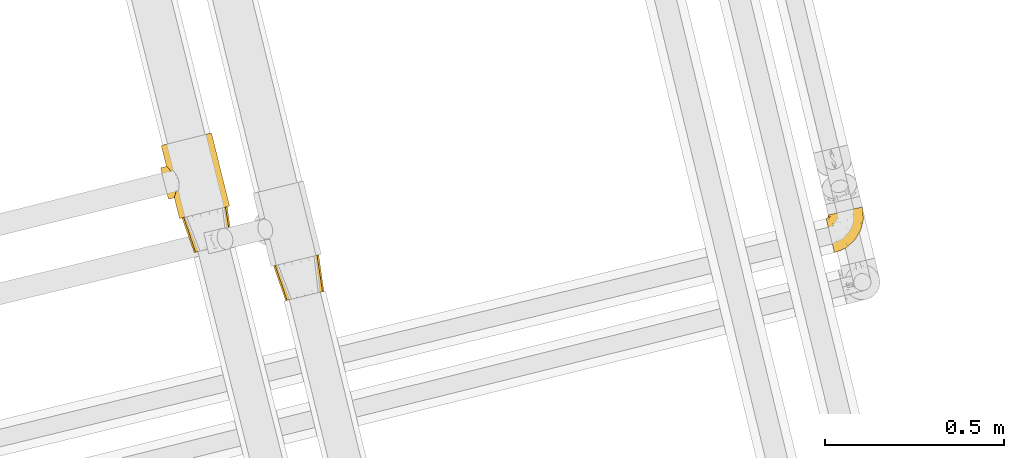
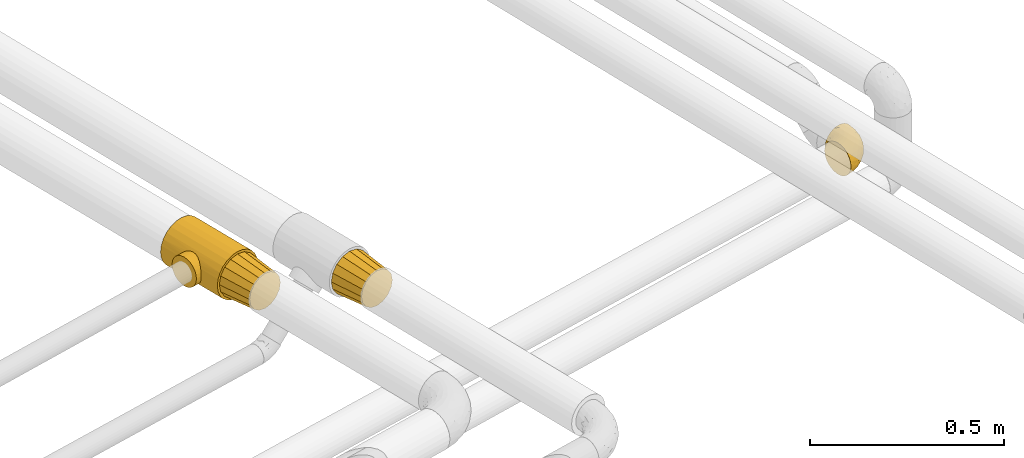
# One storey, part 7 of 93: 4 coverings.
"""IFC2X3 building model written with IfcOpenShell, lengths in millimetres."""

from ifc_helpers import new_model, entity, si_unit, converted_unit, derived_unit, direction, frame, origin, place, context, subcontext, project, spatial, faceted_brep, element, save


model = new_model("IFC2X3")

# Units and contexts
model_context = context("Model", 3, precision=0.01, world=origin(), true_north=direction((6.12303176911189e-17, 1.0)))
body_context = subcontext(model_context, "Body", "Model", "MODEL_VIEW")
ifc_project = project(units=[si_unit("LENGTHUNIT", "METRE", prefix="MILLI"), si_unit("AREAUNIT", "SQUARE_METRE"), si_unit("VOLUMEUNIT", "CUBIC_METRE"), converted_unit("PLANEANGLEUNIT", "DEGREE", entity("IfcRatioMeasure", 0.0174532925199433), si_unit("PLANEANGLEUNIT", "RADIAN"), dimensions=[0, 0, 0, 0, 0, 0, 0]), si_unit("MASSUNIT", "GRAM", prefix="KILO"), derived_unit("MASSDENSITYUNIT", [(si_unit("MASSUNIT", "GRAM", prefix="KILO"), 1), (si_unit("LENGTHUNIT", "METRE"), -3)]), derived_unit("MOMENTOFINERTIAUNIT", [(si_unit("LENGTHUNIT", "METRE"), 4)]), si_unit("TIMEUNIT", "SECOND"), si_unit("FREQUENCYUNIT", "HERTZ"), si_unit("THERMODYNAMICTEMPERATUREUNIT", "DEGREE_CELSIUS"), derived_unit("THERMALTRANSMITTANCEUNIT", [(si_unit("MASSUNIT", "GRAM", prefix="KILO"), 1), (si_unit("THERMODYNAMICTEMPERATUREUNIT", "KELVIN"), -1), (si_unit("TIMEUNIT", "SECOND"), -3)]), derived_unit("VOLUMETRICFLOWRATEUNIT", [(si_unit("LENGTHUNIT", "METRE"), 3), (si_unit("TIMEUNIT", "SECOND"), -1)]), derived_unit("MASSFLOWRATEUNIT", [(si_unit("MASSUNIT", "GRAM", prefix="KILO"), 1), (si_unit("TIMEUNIT", "SECOND"), -1)]), derived_unit("ROTATIONALFREQUENCYUNIT", [(si_unit("TIMEUNIT", "SECOND"), -1)]), si_unit("ELECTRICCURRENTUNIT", "AMPERE"), si_unit("ELECTRICVOLTAGEUNIT", "VOLT"), si_unit("POWERUNIT", "WATT"), si_unit("FORCEUNIT", "NEWTON", prefix="KILO"), si_unit("ILLUMINANCEUNIT", "LUX"), si_unit("LUMINOUSFLUXUNIT", "LUMEN"), si_unit("LUMINOUSINTENSITYUNIT", "CANDELA"), derived_unit("USERDEFINED", [(si_unit("MASSUNIT", "GRAM", prefix="KILO"), -1), (si_unit("LENGTHUNIT", "METRE"), -2), (si_unit("TIMEUNIT", "SECOND"), 3), (si_unit("LUMINOUSFLUXUNIT", "LUMEN"), 1)]), derived_unit("LINEARVELOCITYUNIT", [(si_unit("LENGTHUNIT", "METRE"), 1), (si_unit("TIMEUNIT", "SECOND"), -1)]), si_unit("PRESSUREUNIT", "PASCAL"), derived_unit("USERDEFINED", [(si_unit("LENGTHUNIT", "METRE"), -2), (si_unit("MASSUNIT", "GRAM", prefix="KILO"), 1), (si_unit("TIMEUNIT", "SECOND"), -2)]), derived_unit("LINEARFORCEUNIT", [(si_unit("MASSUNIT", "GRAM", prefix="KILO"), 1), (si_unit("LENGTHUNIT", "METRE"), 1), (si_unit("TIMEUNIT", "SECOND"), -2), (si_unit("LENGTHUNIT", "METRE"), -1)]), derived_unit("PLANARFORCEUNIT", [(si_unit("MASSUNIT", "GRAM", prefix="KILO"), 1), (si_unit("LENGTHUNIT", "METRE"), 1), (si_unit("TIMEUNIT", "SECOND"), -2), (si_unit("LENGTHUNIT", "METRE"), -2)])], contexts=[model_context])

# Site, building, storey
site_placement = place(None, origin())
site = spatial("IfcSite", under=ifc_project, at=site_placement, CompositionType="ELEMENT")
building_placement = place(site_placement, origin())
building = spatial("IfcBuilding", under=site, at=building_placement, CompositionType="ELEMENT")
storey_placement = place(building_placement, frame((0.0, 0.0, -4200.0)))
storey = spatial("IfcBuildingStorey", under=building, at=storey_placement, CompositionType="ELEMENT", Elevation=-4200.0)

# Coverings
covering_1_placement = place(storey_placement, frame((-16206.44, 9622.71, 2434.01)))
element("IfcCovering", 1, at=covering_1_placement, inside=storey, Name=":ADSK_", ObjectType=":ADSK_", PredefinedType="INSULATION", context=body_context, shape_type="Brep", body=[
    faceted_brep([(35.52, 1.6, 66.6), (37.56, 2.09, 56.07), (39.59, 2.59, 45.55), (45.38, 4.0, 36.63), (51.17, 5.42, 27.7), (59.84, 7.54, 21.74), (68.5, 9.65, 15.78), (78.73, 12.15, 13.69), (88.95, 14.65, 11.6), (99.17, 17.15, 13.69), (109.4, 19.65, 15.78), (118.06, 21.77, 21.74), (126.73, 23.88, 27.7), (132.52, 25.3, 36.63), (138.31, 26.71, 45.55), (140.34, 27.21, 56.07), (142.38, 27.71, 66.6), (140.34, 27.21, 77.12), (138.31, 26.71, 87.64), (132.52, 25.3, 96.56), (126.73, 23.88, 105.49), (118.06, 21.77, 111.45), (109.4, 19.65, 117.41), (99.17, 17.15, 119.5), (88.95, 14.65, 121.6), (78.73, 12.15, 119.5), (68.5, 9.65, 117.41), (59.84, 7.54, 111.45), (51.17, 5.42, 105.49), (45.38, 4.0, 96.56), (39.59, 2.59, 87.64), (37.56, 2.09, 77.12), (123.07, 127.99, 91.47), (125.06, 128.48, 81.18), (127.88, 129.17, 66.6), (125.06, 128.48, 52.01), (123.07, 127.99, 41.72), (116.23, 126.32, 31.18), (109.39, 124.65, 20.63), (99.14, 122.14, 13.59), (88.9, 119.64, 6.54), (78.91, 117.2, 4.5), (64.74, 113.74, 1.6), (50.57, 110.27, 4.5), (40.57, 107.83, 6.54), (30.33, 105.33, 13.59), (20.09, 102.83, 20.63), (13.25, 101.15, 31.18), (6.4, 99.48, 41.72), (4.41, 98.99, 52.01), (1.6, 98.31, 66.6), (4.41, 98.99, 81.18), (6.4, 99.48, 91.47), (13.25, 101.15, 102.01), (20.09, 102.83, 112.56), (30.33, 105.33, 119.6), (40.57, 107.83, 126.65), (50.57, 110.27, 128.69), (64.74, 113.74, 131.6), (78.91, 117.2, 128.69), (88.9, 119.64, 126.65), (99.14, 122.14, 119.6), (109.39, 124.65, 112.56), (116.23, 126.32, 102.01)], [[[0, 1, 2, 3, 4, 5, 6, 7, 8, 9, 10, 11, 12, 13, 14, 15, 16, 17, 18, 19, 20, 21, 22, 23, 24, 25, 26, 27, 28, 29, 30, 31]], [[32, 33, 34, 35, 36, 37, 38, 39, 40, 41, 42, 43, 44, 45, 46, 47, 48, 49, 50, 51, 52, 53, 54, 55, 56, 57, 58, 59, 60, 61, 62, 63]], [[6, 44, 43, 42, 8, 7]], [[45, 44, 6, 5, 4, 46]], [[1, 0, 50, 49, 48, 2]], [[47, 46, 4, 3, 2, 48]], [[14, 36, 35, 34, 16, 15]], [[37, 36, 14, 13, 12, 38]], [[9, 8, 42, 41, 40, 10]], [[39, 38, 12, 11, 10, 40]], [[22, 60, 59, 58, 24, 23]], [[61, 60, 22, 21, 20, 62]], [[17, 16, 34, 33, 32, 18]], [[63, 62, 20, 19, 18, 32]], [[30, 52, 51, 50, 0, 31]], [[53, 52, 30, 29, 28, 54]], [[25, 24, 58, 57, 56, 26]], [[55, 54, 28, 27, 26, 56]]]),
])
covering_2_placement = place(storey_placement, frame((-16521.24, 9851.44, 2426.25)))
element("IfcCovering", 2, at=covering_2_placement, inside=storey, Name=":ADSK_", ObjectType=":ADSK_", PredefinedType="INSULATION", context=body_context, shape_type="Brep", body=[
    faceted_brep([(91.57, 227.34, 143.44), (108.46, 231.55, 136.23), (122.95, 235.17, 124.76), (134.08, 237.95, 109.82), (141.07, 239.69, 92.42), (143.46, 240.29, 73.75), (141.07, 239.69, 55.07), (134.08, 237.95, 37.67), (122.95, 235.17, 22.73), (108.46, 231.55, 11.26), (91.57, 227.34, 4.05), (73.46, 222.82, 1.6), (55.34, 218.29, 4.05), (38.45, 214.08, 11.26), (23.96, 210.46, 22.73), (12.83, 207.69, 37.67), (9.33, 206.81, 46.37), (5.84, 205.94, 55.07), (4.64, 205.64, 64.41), (3.45, 205.35, 73.75), (4.64, 205.64, 83.08), (5.84, 205.94, 92.42), (9.33, 206.81, 101.12), (12.83, 207.69, 109.82), (23.96, 210.46, 124.76), (38.45, 214.08, 136.23), (55.34, 218.29, 143.44), (73.46, 222.82, 145.9), (124.3, 19.07, 1.6), (142.42, 23.59, 4.05), (159.31, 27.8, 11.26), (173.8, 31.42, 22.73), (184.93, 34.19, 37.67), (191.92, 35.94, 55.07), (194.31, 36.54, 73.75), (191.92, 35.94, 92.42), (184.93, 34.19, 109.82), (173.8, 31.42, 124.76), (159.31, 27.8, 136.23), (142.42, 23.59, 143.44), (124.3, 19.07, 145.9), (106.19, 14.54, 143.44), (89.3, 10.33, 136.23), (74.8, 6.71, 124.76), (63.68, 3.94, 109.82), (60.18, 3.06, 101.12), (56.69, 2.19, 92.42), (55.49, 1.89, 83.08), (54.3, 1.6, 73.75), (55.49, 1.89, 64.41), (56.69, 2.19, 55.07), (60.18, 3.06, 46.37), (63.68, 3.94, 37.67), (74.8, 6.71, 22.73), (89.3, 10.33, 11.26), (106.19, 14.54, 4.05), (45.79, 87.26, 33.18), (21.79, 143.46, 53.82), (25.99, 138.98, 45.41), (45.86, 97.11, 29.78), (40.24, 61.0, 63.43), (44.28, 107.31, 28.6), (40.88, 117.07, 29.78), (17.94, 147.28, 73.75), (18.95, 146.3, 63.43), (36.19, 125.72, 33.18), (43.01, 70.77, 45.41), (44.64, 78.37, 38.46), (41.41, 64.84, 53.82), (39.81, 59.66, 73.75), (30.99, 133.04, 38.46), (40.24, 61.0, 84.06), (41.41, 64.84, 93.68), (44.64, 78.37, 109.03), (43.01, 70.77, 102.09), (18.95, 146.3, 84.06), (21.79, 143.46, 93.68), (25.99, 138.98, 102.09), (30.99, 133.04, 109.03), (45.79, 87.26, 114.31), (45.86, 97.11, 117.71), (44.28, 107.31, 118.9), (36.19, 125.72, 114.31), (40.88, 117.07, 117.71), (20.26, 68.41, 41.82), (22.0, 61.45, 51.17), (23.09, 57.08, 62.06), (23.46, 55.58, 73.75), (23.09, 57.08, 85.43), (22.0, 61.45, 96.32), (20.26, 68.41, 105.67), (17.99, 77.49, 112.85), (15.36, 88.05, 117.36), (12.53, 99.39, 118.9), (9.7, 110.73, 117.36), (7.06, 121.29, 112.85), (4.8, 130.37, 105.67), (3.06, 137.33, 96.32), (1.97, 141.7, 85.43), (1.6, 143.2, 73.75), (1.97, 141.7, 62.06), (3.06, 137.33, 51.17), (4.8, 130.37, 41.82), (7.06, 121.29, 34.64), (9.7, 110.73, 30.13), (12.53, 99.39, 28.6), (15.36, 88.05, 30.13), (17.99, 77.49, 34.64)], [[[0, 1, 2, 3, 4, 5, 6, 7, 8, 9, 10, 11, 12, 13, 14, 15, 16, 17, 18, 19, 20, 21, 22, 23, 24, 25, 26, 27]], [[28, 29, 30, 31, 32, 33, 34, 35, 36, 37, 38, 39, 40, 41, 42, 43, 44, 45, 46, 47, 48, 49, 50, 51, 52, 53, 54, 55]], [[32, 31, 8, 7]], [[5, 34, 33, 6]], [[6, 33, 32, 7]], [[9, 30, 29, 10]], [[10, 29, 28, 11]], [[8, 31, 30, 9]], [[55, 12, 11, 28]], [[54, 13, 12, 55]], [[53, 52, 56]], [[57, 16, 58]], [[56, 59, 53]], [[60, 50, 49]], [[54, 53, 14, 13]], [[53, 59, 61]], [[61, 62, 14]], [[63, 18, 64]], [[14, 65, 15]], [[65, 14, 62]], [[66, 52, 51]], [[14, 53, 61]], [[56, 52, 67]], [[67, 52, 66]], [[66, 51, 68]], [[48, 69, 49]], [[63, 19, 18]], [[60, 49, 69]], [[50, 60, 68]], [[50, 68, 51]], [[70, 58, 15]], [[16, 57, 17]], [[58, 16, 15]], [[15, 65, 70]], [[18, 17, 64]], [[64, 17, 57]], [[48, 47, 69]], [[63, 20, 19]], [[71, 47, 46]], [[46, 72, 71]], [[46, 45, 72]], [[44, 73, 74]], [[74, 45, 44]], [[75, 20, 63]], [[76, 22, 21]], [[76, 77, 22]], [[76, 21, 75]], [[77, 78, 23]], [[79, 43, 80]], [[43, 79, 44]], [[69, 47, 71]], [[72, 45, 74]], [[42, 41, 26, 25]], [[24, 43, 42, 25]], [[80, 43, 81]], [[26, 41, 40, 27]], [[24, 82, 83]], [[75, 21, 20]], [[24, 23, 82]], [[23, 78, 82]], [[83, 81, 24]], [[77, 23, 22]], [[81, 43, 24]], [[79, 73, 44]], [[0, 39, 38, 1]], [[1, 38, 37, 2]], [[40, 39, 0, 27]], [[3, 36, 35, 4]], [[4, 35, 34, 5]], [[2, 37, 36, 3]], [[84, 85, 86, 87, 88, 89, 90, 91, 92, 93, 94, 95, 96, 97, 98, 99, 100, 101, 102, 103, 104, 105, 106, 107]], [[60, 87, 86]], [[68, 86, 85]], [[60, 69, 87]], [[66, 68, 85]], [[60, 86, 68]], [[85, 84, 66]], [[84, 107, 67]], [[107, 106, 56]], [[59, 106, 105]], [[67, 107, 56]], [[59, 56, 106]], [[61, 59, 105]], [[84, 67, 66]], [[62, 105, 104]], [[65, 104, 103]], [[61, 105, 62]], [[62, 104, 65]], [[103, 70, 65]], [[103, 102, 70]], [[58, 102, 101]], [[100, 99, 64]], [[57, 101, 100]], [[57, 58, 101]], [[63, 64, 99]], [[57, 100, 64]], [[102, 58, 70]], [[75, 99, 98]], [[76, 98, 97]], [[75, 63, 99]], [[77, 76, 97]], [[75, 98, 76]], [[97, 96, 77]], [[78, 96, 95]], [[95, 94, 82]], [[93, 83, 94]], [[78, 95, 82]], [[83, 82, 94]], [[81, 83, 93]], [[96, 78, 77]], [[80, 93, 92]], [[79, 92, 91]], [[81, 93, 80]], [[80, 92, 79]], [[91, 73, 79]], [[91, 90, 73]], [[74, 90, 89]], [[89, 88, 72]], [[87, 71, 88]], [[72, 74, 89]], [[69, 71, 87]], [[72, 88, 71]], [[90, 74, 73]]]),
])
covering_3_placement = place(storey_placement, frame((-16461.59, 9756.63, 2433.4)))
element("IfcCovering", 3, at=covering_3_placement, inside=storey, Name=":ADSK_", ObjectType=":ADSK_", PredefinedType="INSULATION", context=body_context, shape_type="Brep", body=[
    faceted_brep([(36.0, 1.6, 66.6), (38.03, 2.1, 56.07), (40.06, 2.61, 45.55), (45.84, 4.05, 36.63), (51.63, 5.5, 27.7), (60.28, 7.66, 21.74), (68.94, 9.82, 15.78), (79.15, 12.36, 13.69), (89.36, 14.91, 11.6), (99.57, 17.46, 13.69), (109.78, 20.01, 15.78), (118.44, 22.17, 21.74), (127.09, 24.33, 27.7), (132.88, 25.77, 36.63), (138.66, 27.22, 45.55), (140.69, 27.72, 56.07), (142.72, 28.23, 66.6), (140.69, 27.72, 77.12), (138.66, 27.22, 87.64), (132.88, 25.77, 96.56), (127.09, 24.33, 105.49), (118.44, 22.17, 111.45), (109.78, 20.01, 117.41), (99.57, 17.46, 119.5), (89.36, 14.91, 121.6), (79.15, 12.36, 119.5), (68.94, 9.82, 117.41), (60.28, 7.66, 111.45), (51.63, 5.5, 105.49), (45.84, 4.05, 96.56), (40.06, 2.61, 87.64), (38.03, 2.1, 77.12), (122.93, 128.42, 91.47), (124.91, 128.91, 81.18), (127.73, 129.62, 66.6), (124.91, 128.91, 52.01), (122.93, 128.42, 41.72), (116.09, 126.71, 31.18), (109.26, 125.01, 20.63), (99.03, 122.45, 13.59), (88.8, 119.9, 6.54), (78.81, 117.41, 4.5), (64.66, 113.88, 1.6), (50.51, 110.35, 4.5), (40.53, 107.85, 6.54), (30.3, 105.3, 13.59), (20.07, 102.75, 20.63), (13.23, 101.04, 31.18), (6.4, 99.34, 41.72), (4.41, 98.84, 52.01), (1.6, 98.14, 66.6), (4.41, 98.84, 81.18), (6.4, 99.34, 91.47), (13.23, 101.04, 102.01), (20.07, 102.75, 112.56), (30.3, 105.3, 119.6), (40.53, 107.85, 126.65), (50.51, 110.35, 128.69), (64.66, 113.88, 131.6), (78.81, 117.41, 128.69), (88.8, 119.9, 126.65), (99.03, 122.45, 119.6), (109.26, 125.01, 112.56), (116.09, 126.71, 102.01)], [[[0, 1, 2, 3, 4, 5, 6, 7, 8, 9, 10, 11, 12, 13, 14, 15, 16, 17, 18, 19, 20, 21, 22, 23, 24, 25, 26, 27, 28, 29, 30, 31]], [[32, 33, 34, 35, 36, 37, 38, 39, 40, 41, 42, 43, 44, 45, 46, 47, 48, 49, 50, 51, 52, 53, 54, 55, 56, 57, 58, 59, 60, 61, 62, 63]], [[6, 44, 43, 42, 8, 7]], [[45, 44, 6, 5, 4, 46]], [[1, 0, 50, 49, 48, 2]], [[47, 46, 4, 3, 2, 48]], [[14, 36, 35, 34, 16, 15]], [[37, 36, 14, 13, 12, 38]], [[9, 8, 42, 41, 40, 10]], [[39, 38, 12, 11, 10, 40]], [[22, 60, 59, 58, 24, 23]], [[61, 60, 22, 21, 20, 62]], [[17, 16, 34, 33, 32, 18]], [[63, 62, 20, 19, 18, 32]], [[30, 52, 51, 50, 0, 31]], [[53, 52, 30, 29, 28, 54]], [[25, 24, 58, 57, 56, 26]], [[55, 54, 28, 27, 26, 56]]]),
])
covering_4_placement = place(storey_placement, frame((-14665.38, 9756.17, 2242.1)))
element("IfcCovering", 4, at=covering_4_placement, inside=storey, Name=":ADSK_", ObjectType=":ADSK_", PredefinedType="INSULATION", context=body_context, shape_type="Brep", body=[
    faceted_brep([(8.57, 106.85, 61.69), (12.1, 107.7, 72.08), (17.8, 109.07, 81.4), (25.37, 110.89, 89.18), (34.43, 113.07, 95.03), (39.48, 114.29, 96.85), (44.53, 115.5, 98.66), (49.6, 116.72, 99.25), (52.38, 117.39, 99.57), (55.16, 118.06, 99.9), (65.79, 120.62, 98.66), (75.9, 123.05, 95.02), (84.96, 125.22, 89.17), (92.52, 127.04, 81.38), (98.21, 128.41, 72.06), (101.75, 129.26, 61.68), (102.94, 129.55, 50.75), (101.74, 129.26, 39.8), (98.21, 128.41, 29.41), (92.51, 127.04, 20.09), (84.94, 125.22, 12.31), (75.88, 123.04, 6.46), (65.78, 120.61, 2.83), (55.16, 118.06, 1.6), (49.6, 116.72, 2.24), (44.52, 115.5, 2.83), (39.47, 114.28, 4.65), (34.41, 113.07, 6.47), (25.35, 110.89, 12.32), (17.79, 109.07, 20.11), (12.1, 107.7, 29.43), (8.57, 106.85, 39.81), (7.37, 106.56, 50.75), (1.99, 95.47, 38.02), (3.15, 90.7, 26.17), (5.0, 83.11, 15.99), (6.21, 78.17, 12.09), (7.42, 73.22, 8.18), (8.82, 67.46, 5.73), (10.22, 61.71, 3.27), (11.87, 54.93, 2.35), (12.55, 52.14, 1.97), (13.23, 49.35, 1.6), (16.25, 36.99, 3.27), (19.05, 25.47, 8.18), (21.47, 15.58, 15.99), (23.32, 7.99, 26.17), (24.48, 3.22, 38.02), (24.87, 1.6, 50.75), (24.48, 3.22, 63.47), (23.32, 7.99, 75.32), (21.47, 15.58, 85.5), (19.05, 25.47, 93.31), (16.25, 36.99, 98.22), (13.23, 49.35, 99.9), (11.87, 54.93, 99.14), (10.22, 61.71, 98.22), (8.82, 67.46, 95.77), (7.42, 73.22, 93.31), (6.21, 78.17, 89.4), (5.0, 83.11, 85.5), (3.15, 90.7, 75.32), (1.99, 95.47, 63.47), (1.6, 97.1, 50.75), (85.07, 42.86, 59.29), (75.55, 38.34, 73.11), (70.31, 27.79, 63.74), (55.46, 14.38, 50.75), (45.32, 9.57, 58.65), (36.17, 6.31, 50.75), (59.86, 26.44, 76.75), (47.39, 13.26, 67.69), (40.37, 16.35, 78.93), (77.12, 85.51, 94.32), (67.08, 99.78, 98.75), (63.62, 78.57, 98.4), (39.29, 36.05, 94.57), (60.86, 43.25, 89.92), (57.67, 56.53, 96.34), (33.98, 46.7, 98.79), (33.36, 58.7, 99.9), (28.31, 56.35, 99.9), (23.26, 54.01, 99.9), (20.75, 52.84, 99.9), (18.25, 51.68, 99.9), (44.59, 26.89, 87.32), (76.82, 104.98, 95.6), (102.15, 80.75, 60.46), (103.7, 104.3, 65.24), (98.54, 84.36, 72.88), (56.05, 95.88, 99.9), (54.13, 90.67, 99.9), (52.22, 85.46, 99.9), (50.31, 80.25, 99.9), (48.39, 75.04, 99.9), (85.43, 105.8, 90.65), (96.24, 64.44, 63.07), (70.33, 59.5, 91.92), (99.21, 109.79, 75.25), (103.91, 117.35, 50.75), (68.93, 39.98, 82.2), (78.56, 57.02, 85.12), (84.2, 53.86, 76.93), (97.87, 64.27, 50.75), (89.24, 50.12, 50.75), (93.75, 101.47, 83.02), (55.27, 115.3, 99.9), (55.38, 112.53, 99.9), (55.6, 107.01, 99.9), (55.82, 101.44, 99.9), (87.03, 82.69, 87.14), (89.33, 70.42, 80.75), (49.08, 61.78, 99.17), (105.57, 96.51, 50.75), (44.64, 70.95, 99.9), (40.88, 66.87, 99.9), (37.12, 62.79, 99.9), (80.61, 35.97, 50.75), (87.82, 50.99, 67.57), (93.44, 66.4, 72.15), (101.72, 80.39, 50.75), (68.03, 25.17, 50.75), (45.87, 106.91, 98.69), (17.88, 60.57, 99.01), (26.18, 66.37, 98.78), (19.79, 64.96, 98.29), (20.32, 101.11, 84.1), (11.91, 103.41, 71.06), (44.2, 94.88, 98.54), (48.56, 97.63, 99.29), (13.26, 81.62, 89.5), (10.44, 87.32, 83.58), (9.04, 93.38, 75.73), (15.35, 89.89, 84.78), (13.04, 98.33, 75.87), (7.24, 98.27, 64.77), (25.29, 91.99, 90.82), (32.38, 92.49, 94.63), (26.92, 98.35, 90.37), (11.51, 78.16, 91.18), (25.42, 104.19, 88.63), (23.51, 86.94, 91.61), (18.82, 96.65, 83.9), (39.71, 103.8, 96.86), (6.44, 100.64, 50.75), (8.81, 102.34, 62.92), (41.78, 89.08, 98.37), (42.42, 83.52, 99.0), (35.41, 83.67, 97.36), (18.85, 73.31, 95.54), (30.23, 69.65, 98.76), (22.91, 76.97, 95.26), (33.3, 76.9, 98.03), (18.78, 83.86, 90.61), (32.44, 103.91, 93.48), (33.04, 98.11, 94.16), (34.82, 71.69, 99.1), (9.04, 93.38, 25.76), (18.76, 83.86, 10.89), (10.43, 87.32, 17.9), (15.33, 89.88, 16.72), (11.9, 103.41, 30.45), (13.26, 81.61, 11.98), (39.69, 103.8, 4.64), (20.31, 101.11, 17.4), (15.74, 50.51, 1.6), (23.26, 54.01, 1.6), (18.25, 51.68, 1.6), (25.4, 104.18, 12.88), (26.91, 98.34, 11.13), (19.79, 64.96, 3.2), (18.85, 73.31, 5.95), (11.51, 78.16, 10.31), (32.4, 103.92, 8.04), (43.88, 95.04, 3.03), (33.02, 98.11, 7.34), (17.88, 60.57, 2.48), (30.23, 69.65, 2.73), (26.51, 66.16, 2.63), (55.6, 107.01, 1.6), (45.87, 106.9, 2.8), (7.23, 98.26, 36.71), (28.31, 56.35, 1.6), (33.36, 58.7, 1.6), (8.8, 102.34, 38.59), (55.38, 112.53, 1.6), (55.49, 109.77, 1.6), (41.78, 89.08, 3.12), (18.81, 96.65, 17.6), (50.31, 80.25, 1.6), (42.39, 83.51, 2.5), (32.38, 92.47, 6.86), (33.3, 76.9, 3.46), (23.48, 86.94, 9.9), (35.34, 83.69, 4.15), (55.82, 101.44, 1.6), (56.05, 95.88, 1.6), (13.03, 98.33, 25.63), (25.27, 91.98, 10.68), (34.82, 71.7, 2.39), (40.88, 66.87, 1.6), (22.91, 76.97, 6.23), (37.12, 62.79, 1.6), (48.56, 97.63, 2.2), (44.64, 70.95, 1.6), (48.39, 75.04, 1.6), (52.22, 85.46, 1.6), (54.13, 90.67, 1.6), (49.44, 61.56, 2.4), (45.32, 9.57, 42.84), (44.6, 26.89, 14.17), (60.63, 43.07, 11.55), (68.89, 39.97, 19.26), (59.86, 26.45, 24.74), (75.56, 38.39, 28.35), (76.96, 105.26, 5.95), (67.35, 99.64, 2.8), (33.98, 46.7, 2.7), (70.31, 27.79, 37.75), (47.4, 13.26, 33.8), (40.38, 16.36, 22.56), (39.29, 36.05, 6.92), (98.54, 84.36, 28.6), (103.69, 104.3, 36.23), (102.14, 80.74, 41.02), (84.24, 53.94, 24.55), (87.82, 50.99, 33.92), (77.15, 86.19, 7.1), (96.24, 64.4, 38.45), (85.07, 42.86, 42.2), (93.73, 101.47, 18.45), (85.41, 105.79, 10.83), (89.39, 70.5, 20.79), (93.46, 66.41, 29.36), (63.65, 78.56, 3.1), (73.1, 65.46, 9.17), (99.2, 109.78, 26.22), (86.97, 82.5, 14.34), (58.29, 56.15, 5.45), (78.55, 57.03, 16.36)], [[[0, 1, 2, 3, 4, 5, 6, 7, 8, 9, 10, 11, 12, 13, 14, 15, 16, 17, 18, 19, 20, 21, 22, 23, 24, 25, 26, 27, 28, 29, 30, 31, 32]], [[33, 34, 35, 36, 37, 38, 39, 40, 41, 42, 43, 44, 45, 46, 47, 48, 49, 50, 51, 52, 53, 54, 55, 56, 57, 58, 59, 60, 61, 62, 63]], [[64, 65, 66]], [[67, 68, 69]], [[66, 70, 71]], [[71, 70, 72]], [[73, 74, 75]], [[76, 77, 78]], [[50, 49, 71]], [[79, 80, 81, 82, 83, 84, 54]], [[51, 85, 52]], [[72, 51, 50]], [[11, 10, 86]], [[87, 88, 89]], [[75, 90, 91, 92, 93, 94]], [[54, 53, 79]], [[76, 52, 85]], [[14, 88, 15]], [[86, 74, 73]], [[95, 12, 11]], [[87, 89, 96]], [[97, 78, 77]], [[88, 14, 98]], [[72, 85, 51]], [[98, 14, 13]], [[88, 99, 15]], [[77, 100, 101]], [[100, 65, 102]], [[103, 96, 104]], [[105, 13, 12]], [[74, 9, 106, 107, 108, 109, 90]], [[105, 110, 111]], [[112, 75, 94]], [[87, 113, 88]], [[112, 94, 114, 115, 116, 80]], [[73, 95, 86]], [[117, 64, 66]], [[49, 69, 68]], [[98, 89, 88]], [[97, 75, 78]], [[100, 102, 101]], [[95, 105, 12]], [[78, 79, 76]], [[105, 95, 110]], [[66, 71, 68]], [[64, 96, 118]], [[76, 79, 53]], [[112, 79, 78]], [[52, 76, 53]], [[76, 85, 77]], [[100, 85, 70]], [[77, 101, 97]], [[13, 105, 98]], [[89, 98, 105]], [[86, 95, 11]], [[110, 95, 73]], [[97, 110, 73]], [[101, 102, 111]], [[89, 119, 96]], [[87, 103, 120, 113]], [[99, 88, 113]], [[99, 16, 15]], [[86, 10, 74]], [[9, 74, 10]], [[90, 75, 74]], [[71, 72, 50]], [[85, 72, 70]], [[79, 112, 80]], [[75, 112, 78]], [[85, 100, 77]], [[65, 100, 70]], [[66, 65, 70]], [[65, 118, 102]], [[118, 119, 102]], [[102, 119, 111]], [[119, 118, 96]], [[89, 105, 111]], [[89, 111, 119]], [[101, 111, 110]], [[104, 96, 64]], [[103, 87, 96]], [[104, 64, 117]], [[65, 64, 118]], [[66, 67, 121, 117]], [[49, 48, 69]], [[49, 68, 71]], [[110, 97, 101]], [[75, 97, 73]], [[67, 66, 68]], [[5, 122, 108]], [[82, 81, 123]], [[124, 80, 116]], [[58, 57, 125]], [[126, 1, 127]], [[128, 91, 129]], [[60, 130, 131]], [[132, 133, 134]], [[135, 63, 62]], [[62, 132, 135]], [[136, 137, 138]], [[109, 108, 122, 90]], [[132, 134, 135]], [[132, 62, 61]], [[130, 60, 139]], [[123, 57, 56]], [[140, 126, 138]], [[140, 2, 126]], [[125, 81, 80]], [[4, 122, 5]], [[106, 9, 8, 7, 6, 108, 107]], [[6, 5, 108]], [[141, 136, 142]], [[4, 143, 122]], [[56, 55, 54, 84, 83, 82]], [[144, 145, 32]], [[145, 135, 134]], [[1, 126, 2]], [[93, 92, 146]], [[1, 0, 127]], [[142, 136, 126]], [[122, 143, 129]], [[125, 57, 123]], [[147, 137, 148]], [[125, 124, 149]], [[149, 58, 125]], [[150, 149, 124]], [[151, 152, 153]], [[151, 130, 139]], [[143, 4, 3]], [[140, 154, 3]], [[155, 146, 128]], [[131, 61, 60]], [[132, 131, 133]], [[134, 127, 145]], [[63, 135, 144]], [[156, 150, 115]], [[150, 116, 115]], [[151, 149, 150]], [[156, 114, 152]], [[141, 148, 136]], [[151, 150, 156]], [[130, 151, 153]], [[130, 153, 131]], [[139, 60, 59]], [[133, 131, 153]], [[132, 61, 131]], [[141, 133, 153]], [[141, 142, 133]], [[153, 152, 141]], [[148, 141, 152]], [[152, 94, 148]], [[146, 92, 128]], [[80, 124, 125]], [[116, 150, 124]], [[94, 93, 147]], [[137, 146, 155]], [[147, 93, 146]], [[91, 90, 129]], [[128, 143, 154]], [[128, 92, 91]], [[127, 0, 145]], [[127, 134, 142]], [[32, 145, 0]], [[144, 135, 145]], [[82, 123, 56]], [[125, 123, 81]], [[138, 137, 155]], [[148, 137, 136]], [[138, 155, 140]], [[136, 138, 126]], [[154, 140, 155]], [[3, 2, 140]], [[128, 154, 155]], [[143, 3, 154]], [[122, 129, 90]], [[128, 129, 143]], [[127, 142, 126]], [[133, 142, 134]], [[59, 149, 139]], [[58, 149, 59]], [[139, 149, 151]], [[114, 94, 152]], [[151, 156, 152]], [[156, 115, 114]], [[137, 147, 146]], [[94, 147, 148]], [[34, 33, 157]], [[158, 159, 160]], [[31, 30, 161]], [[35, 159, 162]], [[28, 27, 163]], [[164, 30, 29]], [[165, 42, 41, 40, 39, 166, 167]], [[168, 169, 164]], [[170, 37, 171]], [[36, 35, 172]], [[173, 174, 175]], [[39, 176, 166]], [[177, 178, 171]], [[26, 179, 180]], [[63, 144, 181]], [[182, 170, 183]], [[32, 31, 184]], [[170, 38, 37]], [[24, 23, 185, 186, 179, 25]], [[176, 39, 38]], [[187, 175, 174]], [[188, 161, 164]], [[33, 181, 157]], [[175, 169, 168]], [[189, 190, 187]], [[27, 180, 163]], [[169, 175, 191]], [[192, 193, 194]], [[195, 196, 180, 179]], [[179, 26, 25]], [[27, 26, 180]], [[197, 157, 181]], [[188, 164, 198]], [[184, 161, 197]], [[199, 200, 177]], [[182, 176, 170]], [[158, 201, 162]], [[202, 178, 177]], [[202, 177, 200]], [[196, 203, 180]], [[203, 174, 163]], [[168, 173, 175]], [[197, 188, 160]], [[162, 159, 158]], [[63, 181, 33]], [[161, 184, 31]], [[171, 201, 177]], [[170, 178, 183]], [[201, 192, 199]], [[193, 158, 160]], [[192, 204, 199]], [[36, 172, 171]], [[192, 201, 158]], [[172, 201, 171]], [[159, 35, 34]], [[34, 157, 159]], [[160, 159, 157]], [[197, 160, 157]], [[160, 188, 193]], [[194, 193, 198]], [[192, 158, 193]], [[187, 191, 175]], [[205, 192, 194]], [[183, 178, 202]], [[171, 178, 170]], [[187, 206, 189]], [[205, 194, 190]], [[191, 194, 198]], [[164, 161, 30]], [[206, 187, 174]], [[207, 203, 196]], [[207, 206, 174]], [[184, 197, 181]], [[181, 144, 184]], [[32, 184, 144]], [[170, 176, 38]], [[166, 176, 182]], [[191, 187, 190]], [[169, 198, 164]], [[198, 169, 191]], [[168, 164, 29]], [[29, 28, 168]], [[173, 168, 28]], [[28, 163, 173]], [[174, 173, 163]], [[174, 203, 207]], [[180, 203, 163]], [[188, 198, 193]], [[161, 188, 197]], [[171, 37, 36]], [[35, 162, 172]], [[201, 172, 162]], [[201, 199, 177]], [[205, 190, 189]], [[204, 192, 205]], [[204, 200, 199]], [[191, 190, 194]], [[208, 183, 202, 200, 204, 205]], [[47, 209, 69]], [[210, 211, 212]], [[213, 212, 214]], [[215, 216, 22]], [[217, 42, 165, 167, 166, 182, 183]], [[218, 219, 213]], [[46, 45, 220]], [[209, 47, 219]], [[210, 221, 211]], [[221, 44, 43]], [[220, 219, 46]], [[46, 219, 47]], [[220, 210, 213]], [[222, 223, 224]], [[210, 45, 44]], [[225, 226, 214]], [[42, 217, 43]], [[216, 215, 227]], [[226, 228, 229]], [[23, 22, 216]], [[223, 18, 17]], [[19, 230, 20]], [[20, 231, 21]], [[232, 222, 233]], [[234, 205, 189, 206, 207, 196]], [[235, 234, 227]], [[221, 43, 217]], [[104, 229, 228]], [[223, 236, 18]], [[231, 237, 227]], [[18, 236, 19]], [[113, 223, 99]], [[238, 234, 235]], [[231, 20, 230]], [[222, 230, 236]], [[223, 17, 99]], [[222, 228, 233]], [[224, 113, 120, 103]], [[215, 21, 231]], [[208, 234, 238]], [[209, 218, 67]], [[218, 213, 214]], [[229, 117, 218]], [[208, 217, 183]], [[238, 211, 221]], [[238, 221, 217]], [[44, 221, 210]], [[235, 211, 238]], [[212, 211, 239]], [[222, 236, 223]], [[230, 19, 236]], [[237, 231, 230]], [[215, 231, 227]], [[232, 230, 222]], [[235, 237, 239]], [[113, 224, 223]], [[233, 228, 226]], [[17, 16, 99]], [[234, 208, 205]], [[217, 208, 238]], [[216, 227, 234]], [[22, 21, 215]], [[234, 196, 216]], [[216, 196, 195, 179, 186, 185, 23]], [[210, 220, 45]], [[219, 220, 213]], [[69, 209, 67]], [[69, 48, 47]], [[218, 209, 219]], [[225, 214, 212]], [[210, 212, 213]], [[225, 212, 239]], [[214, 226, 229]], [[232, 239, 237]], [[233, 226, 225]], [[232, 233, 225]], [[228, 222, 224]], [[239, 232, 225]], [[232, 237, 230]], [[224, 103, 228]], [[228, 103, 104]], [[104, 117, 229]], [[121, 67, 218, 117]], [[214, 229, 218]], [[237, 235, 227]], [[211, 235, 239]]]),
])

save(model, "model.ifc")
